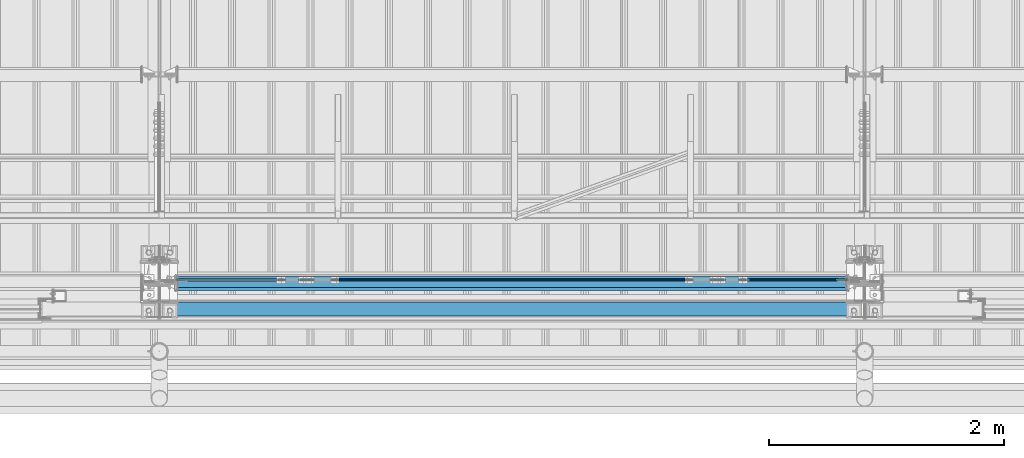
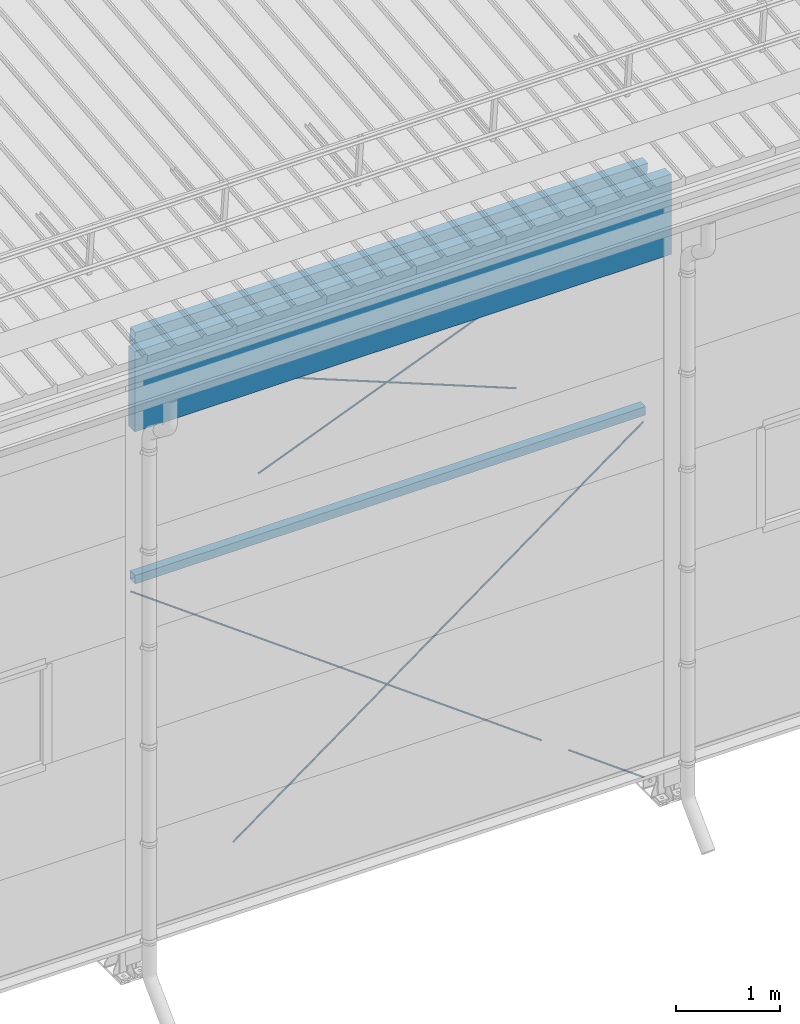
# One storey, part 253 of 709: 5 members, 3 beams, 5 openings, 8 elements without a shape of their own.
"""IFC4 building model written with IfcOpenShell, lengths in millimetres."""

from ifc_helpers import new_model, si_unit, direction, frame, origin_with_axes, place, context, subcontext, project, spatial, line, indexed_curve, outline, extrude, polygons, material, element, aggregate, save


model = new_model("IFC4")

# Units and contexts
model_context = context("Model", 3, precision=0.2, world=origin_with_axes(), true_north=direction((0.0, 1.0)))
body_context = subcontext(model_context, "Body", "Model", "MODEL_VIEW")
reference_context = subcontext(model_context, "Reference", "Model", "MODEL_VIEW")
ifc_project = project(units=[si_unit("LENGTHUNIT", "METRE", prefix="MILLI"), si_unit("AREAUNIT", "SQUARE_METRE"), si_unit("VOLUMEUNIT", "CUBIC_METRE"), si_unit("MASSUNIT", "GRAM", prefix="KILO"), si_unit("TIMEUNIT", "SECOND"), si_unit("PLANEANGLEUNIT", "RADIAN"), si_unit("SOLIDANGLEUNIT", "STERADIAN"), si_unit("THERMODYNAMICTEMPERATUREUNIT", "DEGREE_CELSIUS"), si_unit("LUMINOUSINTENSITYUNIT", "LUMEN")], contexts=[model_context])

# Site, building, storey
site_placement = place(None, origin_with_axes())
site = spatial("IfcSite", under=ifc_project, at=site_placement, CompositionType="ELEMENT")
building_placement = place(site_placement, origin_with_axes())
building = spatial("IfcBuilding", under=site, at=building_placement, Name="Undefined", CompositionType="ELEMENT")
storey_placement = place(building_placement, origin_with_axes())
storey = spatial("IfcBuildingStorey", under=building, at=storey_placement, Name="Undefined", CompositionType="ELEMENT", Elevation=0.0)

# Assembly, beam
assembly_1_placement = place(storey_placement, frame((22000.0, 173.0, 4310.0), z_axis=(0.0, 0.0, -1.0), x_axis=(1.0, 0.0, 0.0)))
assembly_1 = element("IfcElementAssembly", 1, at=assembly_1_placement, inside=storey)
ifc_material_1 = material(Name="C355", Category="STEEL")
beam_1_placement = place(assembly_1_placement, origin_with_axes())
beam_1 = element("IfcBeam", 2, at=beam_1_placement, material=ifc_material_1, ObjectType="546", context=body_context, shape_type="Tessellation", body=[
    polygons([(155.0, -47.0, -47.0), (155.0, -47.0, 47.0), (5845.0, -47.0, 47.0), (5845.0, -47.0, -47.0), (155.0, 47.0, 47.0), (5845.0, 47.0, 47.0), (155.0, 47.0, -47.0), (5845.0, 47.0, -47.0), (155.0, -50.0, -50.0), (155.0, 50.0, -50.0), (5845.0, 50.0, -50.0), (5845.0, -50.0, -50.0), (155.0, 50.0, 50.0), (5845.0, 50.0, 50.0), (155.0, -50.0, 50.0), (5845.0, -50.0, 50.0)], [[[1, 2, 3, 4]], [[2, 5, 6, 3]], [[5, 7, 8, 6]], [[7, 1, 4, 8]], [[9, 10, 11, 12]], [[10, 13, 14, 11]], [[13, 15, 16, 14]], [[15, 9, 12, 16]], [[14, 16, 12, 11], [6, 8, 4, 3]], [[15, 13, 10, 9], [7, 5, 2, 1]]], closed=True),
])
aggregate(assembly_1, [beam_1])

# Assembly, member, voiding feature
assembly_2_placement = place(storey_placement, frame((23129.07626, 189.0, 672.76012), z_axis=(0.0, -1.0, 0.0), x_axis=(0.8064830392, 0.0, 0.5912572262)))
assembly_2 = element("IfcElementAssembly", 3, at=assembly_2_placement, inside=storey)
ifc_material_2 = material(Name="C355-5", Category="STEEL")
member_1_placement = place(assembly_2_placement, origin_with_axes())
member_1 = element("IfcMember", 4, at=member_1_placement, material=ifc_material_2, ObjectType="549", context=body_context, shape_type="Tessellation", body=[
    polygons([(5861.83429, -5.0, 8.66025), (5861.83429, -7.07107, 7.07107), (5861.83429, -8.66025, 5.0), (5861.83429, -9.65926, 2.58819), (5861.83429, -10.0, 0.0), (5861.83429, -9.65926, -2.58819), (5861.83429, -8.66025, -5.0), (5861.83429, -7.07107, -7.07107), (5861.83429, -5.0, -8.66025), (5861.83429, -2.58819, -9.65926), (5861.83429, 0.0, -10.0), (5861.83429, 2.58819, -9.65926), (5861.83429, 5.0, -8.66025), (5861.83429, 7.07107, -7.07107), (5861.83429, 8.66025, -5.0), (5861.83429, 9.65926, -2.58819), (5861.83429, 10.0, 0.0), (5861.83429, 9.65926, 2.58819), (5861.83429, 8.66025, 5.0), (5861.83429, 7.07107, 7.07107), (5861.83429, 5.0, 8.66025), (5861.83429, 2.58819, 9.65926), (5861.83429, 0.0, 10.0), (5861.83429, -2.58819, 9.65926), (190.0, 10.0, 0.0), (190.0, 9.65926, 2.58819), (190.0, 8.66025, 5.0), (190.0, 7.07107, 7.07107), (190.0, 5.0, 8.66025), (190.0, 2.58819, 9.65926), (190.0, 0.0, 10.0), (190.0, -2.58819, 9.65926), (190.0, -5.0, 8.66025), (190.0, -7.07107, 7.07107), (190.0, -8.66025, 5.0), (190.0, -9.65926, 2.58819), (190.0, -10.0, 0.0), (190.0, -9.65926, -2.58819), (190.0, -8.66025, -5.0), (190.0, -7.07107, -7.07107), (190.0, -5.0, -8.66025), (190.0, -2.58819, -9.65926), (190.0, 0.0, -10.0), (190.0, 2.58819, -9.65926), (190.0, 5.0, -8.66025), (190.0, 7.07107, -7.07107), (190.0, 8.66025, -5.0), (190.0, 9.65926, -2.58819), (10.0, 7.36122, 4.25), (190.0, 7.36122, 4.25), (190.0, 8.21037, 2.19996), (10.0, 8.21037, 2.19996), (10.0, 6.01041, 6.01041), (190.0, 6.01041, 6.01041), (10.0, 4.25, 7.36122), (190.0, 4.25, 7.36122), (10.0, 2.19996, 8.21037), (190.0, 2.19996, 8.21037), (10.0, 0.0, 8.5), (190.0, 0.0, 8.5), (10.0, -2.19996, 8.21037), (190.0, -2.19996, 8.21037), (10.0, -4.25, 7.36122), (190.0, -4.25, 7.36122), (10.0, -6.01041, 6.01041), (190.0, -6.01041, 6.01041), (10.0, -7.36122, 4.25), (190.0, -7.36122, 4.25), (10.0, -8.21037, 2.19996), (190.0, -8.21037, 2.19996), (10.0, -8.5, 0.0), (190.0, -8.5, 0.0), (10.0, -8.21037, -2.19996), (190.0, -8.21037, -2.19996), (10.0, -7.36122, -4.25), (190.0, -7.36122, -4.25), (10.0, -6.01041, -6.01041), (190.0, -6.01041, -6.01041), (10.0, -4.25, -7.36122), (190.0, -4.25, -7.36122), (10.0, -2.19996, -8.21037), (190.0, -2.19996, -8.21037), (10.0, 0.0, -8.5), (190.0, 0.0, -8.5), (10.0, 2.19996, -8.21037), (190.0, 2.19996, -8.21037), (10.0, 4.25, -7.36122), (190.0, 4.25, -7.36122), (10.0, 6.01041, -6.01041), (190.0, 6.01041, -6.01041), (10.0, 7.36122, -4.25), (190.0, 7.36122, -4.25), (10.0, 8.21037, -2.19996), (190.0, 8.21037, -2.19996), (10.0, 8.5, 0.0), (190.0, 8.5, 0.0)], [[[1, 2, 3, 4, 5, 6, 7, 8, 9, 10, 11, 12, 13, 14, 15, 16, 17, 18, 19, 20, 21, 22, 23, 24]], [[18, 17, 25, 26]], [[19, 18, 26, 27]], [[20, 19, 27, 28]], [[21, 20, 28, 29]], [[22, 21, 29, 30]], [[23, 22, 30, 31]], [[24, 23, 31, 32]], [[1, 24, 32, 33]], [[2, 1, 33, 34]], [[3, 2, 34, 35]], [[4, 3, 35, 36]], [[5, 4, 36, 37]], [[6, 5, 37, 38]], [[7, 6, 38, 39]], [[8, 7, 39, 40]], [[9, 8, 40, 41]], [[10, 9, 41, 42]], [[11, 10, 42, 43]], [[12, 11, 43, 44]], [[13, 12, 44, 45]], [[14, 13, 45, 46]], [[15, 14, 46, 47]], [[16, 15, 47, 48]], [[17, 16, 48, 25]], [[25, 48, 47, 46, 45, 44, 43, 42, 41, 40, 39, 38, 37, 36, 35, 34, 33, 32, 31, 30, 29, 28, 27, 26], [74, 76, 78, 80, 82, 84, 86, 88, 90, 92, 94, 96, 51, 50, 54, 56, 58, 60, 62, 64, 66, 68, 70, 72]], [[49, 50, 51, 52]], [[53, 54, 50, 49]], [[55, 56, 54, 53]], [[57, 58, 56, 55]], [[59, 60, 58, 57]], [[61, 62, 60, 59]], [[63, 64, 62, 61]], [[65, 66, 64, 63]], [[67, 68, 66, 65]], [[69, 70, 68, 67]], [[71, 72, 70, 69]], [[73, 74, 72, 71]], [[75, 76, 74, 73]], [[77, 78, 76, 75]], [[79, 80, 78, 77]], [[81, 82, 80, 79]], [[83, 84, 82, 81]], [[85, 86, 84, 83]], [[87, 88, 86, 85]], [[89, 90, 88, 87]], [[91, 92, 90, 89]], [[93, 94, 92, 91]], [[95, 96, 94, 93]], [[52, 51, 96, 95]], [[91, 89, 87, 85, 83, 81, 79, 77, 75, 73, 71, 69, 67, 65, 63, 61, 59, 57, 55, 53, 49, 52, 95, 93]]], closed=True),
])
voiding_feature_1_placement = place(member_1_placement, frame((10.0, 0.0, 0.0), z_axis=(0.0, -1.0, 0.0), x_axis=(1.0, 0.0, 0.0)))
element("IfcVoidingFeature", 5, at=voiding_feature_1_placement, cuts=member_1, PredefinedType="HOLE", context=reference_context, identifier="Reference", shape_type="SolidModel", body=[
    extrude(outline(indexed_curve([(10.5, 0.0), (10.14222, 2.7176), (9.09327, 5.25), (7.42462, 7.42462), (5.25, 9.09327), (2.7176, 10.14222), (0.0, 10.5), (-2.7176, 10.14222), (-5.25, 9.09327), (-7.42462, 7.42462), (-9.09327, 5.25), (-10.14222, 2.7176), (-10.5, 0.0), (-10.14222, -2.7176), (-9.09327, -5.25), (-7.42462, -7.42462), (-5.25, -9.09327), (-2.7176, -10.14222), (0.0, -10.5), (2.7176, -10.14222), (5.25, -9.09327), (7.42462, -7.42462), (9.09327, -5.25), (10.14222, -2.7176)], segments=[line(1, 2, 3, 4, 5, 6, 7, 8, 9, 10, 11, 12, 13, 14, 15, 16, 17, 18, 19, 20, 21, 22, 23, 24, 1)])), frame((0.0, 0.0, 0.0), z_axis=(-1.0, 0.0, 0.0), x_axis=(0.0, 0.0, 1.0)), (0.0, 0.0, -1.0), 180.0),
])
aggregate(assembly_2, [member_1])

assembly_3_placement = place(storey_placement, frame((22087.0, 189.0, 4180.0), z_axis=(0.0, -1.0, 0.0), x_axis=(0.8064830392, 0.0, -0.5912572261)))
assembly_3 = element("IfcElementAssembly", 6, at=assembly_3_placement, inside=storey)
member_2_placement = place(assembly_3_placement, origin_with_axes())
member_2 = element("IfcMember", 7, at=member_2_placement, material=ifc_material_2, ObjectType="549", context=body_context, shape_type="Tessellation", body=[
    polygons([(5921.83429, 7.36122, 4.25), (5921.83429, 6.01041, 6.01041), (5921.83429, 4.25, 7.36122), (5921.83429, 2.19996, 8.21037), (5921.83429, 0.0, 8.5), (5921.83429, -2.19996, 8.21037), (5921.83429, -4.25, 7.36122), (5921.83429, -6.0104, 6.01041), (5921.83429, -7.36121, 4.25), (5921.83429, -8.21037, 2.19996), (5921.83429, -8.5, 0.0), (5921.83429, -8.21037, -2.19996), (5921.83429, -7.36121, -4.25), (5921.83429, -6.0104, -6.01041), (5921.83429, -4.25, -7.36122), (5921.83429, -2.19996, -8.21037), (5921.83429, 0.0, -8.5), (5921.83429, 2.19996, -8.21037), (5921.83429, 4.25, -7.36122), (5921.83429, 6.01041, -6.01041), (5921.83429, 7.36122, -4.25), (5921.83429, 8.21037, -2.19996), (5921.83429, 8.5, 0.0), (5921.83429, 8.21037, 2.19996), (5741.83429, 8.21037, 2.19996), (5741.83429, 7.36122, 4.25), (5741.83429, 6.01041, 6.01041), (5741.83429, 4.25, 7.36122), (5741.83429, 2.19996, 8.21037), (5741.83429, 0.0, 8.5), (5741.83429, -2.19996, 8.21037), (5741.83429, -4.25, 7.36122), (5741.83429, -6.0104, 6.01041), (5741.83429, -7.36121, 4.25), (5741.83429, -8.21037, 2.19996), (5741.83429, -8.5, 0.0), (5741.83429, -8.21037, -2.19996), (5741.83429, -7.36121, -4.25), (5741.83429, -6.0104, -6.01041), (5741.83429, -4.25, -7.36122), (5741.83429, -2.19996, -8.21037), (5741.83429, 0.0, -8.5), (5741.83429, 2.19996, -8.21037), (5741.83429, 4.25, -7.36122), (5741.83429, 6.01041, -6.01041), (5741.83429, 7.36122, -4.25), (5741.83429, 8.21037, -2.19996), (5741.83429, 8.5, 0.0), (5741.83429, 10.0, 0.0), (5741.83429, 9.65926, 2.58819), (5741.83429, 8.66025, 5.0), (5741.83429, 7.07107, 7.07107), (5741.83429, 5.0, 8.66025), (5741.83429, 2.58819, 9.65926), (5741.83429, 0.0, 10.0), (5741.83429, -2.58819, 9.65926), (5741.83429, -5.0, 8.66025), (5741.83429, -7.07107, 7.07107), (5741.83429, -8.66025, 5.0), (5741.83429, -9.65926, 2.58819), (5741.83429, -10.0, 0.0), (5741.83429, -9.65926, -2.58819), (5741.83429, -8.66025, -5.0), (5741.83429, -7.07107, -7.07107), (5741.83429, -5.0, -8.66025), (5741.83429, -2.58819, -9.65926), (5741.83429, 0.0, -10.0), (5741.83429, 2.58819, -9.65926), (5741.83429, 5.0, -8.66025), (5741.83429, 7.07107, -7.07107), (5741.83429, 8.66025, -5.0), (5741.83429, 9.65926, -2.58819), (70.0, 2.58819, 9.65926), (70.0, 5.0, 8.66025), (70.0, 7.07107, 7.07107), (70.0, 8.66025, 5.0), (70.0, 9.65926, 2.58819), (70.0, 10.0, 0.0), (70.0, 9.65926, -2.58819), (70.0, 8.66025, -5.0), (70.0, 7.07107, -7.07107), (70.0, 5.0, -8.66025), (70.0, 2.58819, -9.65926), (70.0, 0.0, -10.0), (70.0, -2.58819, -9.65926), (70.0, -5.0, -8.66025), (70.0, -7.07107, -7.07107), (70.0, -8.66025, -5.0), (70.0, -9.65926, -2.58819), (70.0, -10.0, 0.0), (70.0, -9.65926, 2.58819), (70.0, -8.66025, 5.0), (70.0, -7.07107, 7.07107), (70.0, -5.0, 8.66025), (70.0, -2.58819, 9.65926), (70.0, 0.0, 10.0)], [[[1, 2, 3, 4, 5, 6, 7, 8, 9, 10, 11, 12, 13, 14, 15, 16, 17, 18, 19, 20, 21, 22, 23, 24]], [[24, 25, 26, 1]], [[1, 26, 27, 2]], [[2, 27, 28, 3]], [[3, 28, 29, 4]], [[4, 29, 30, 5]], [[5, 30, 31, 6]], [[6, 31, 32, 7]], [[7, 32, 33, 8]], [[8, 33, 34, 9]], [[9, 34, 35, 10]], [[10, 35, 36, 11]], [[11, 36, 37, 12]], [[12, 37, 38, 13]], [[13, 38, 39, 14]], [[14, 39, 40, 15]], [[15, 40, 41, 16]], [[16, 41, 42, 17]], [[17, 42, 43, 18]], [[18, 43, 44, 19]], [[19, 44, 45, 20]], [[20, 45, 46, 21]], [[21, 46, 47, 22]], [[22, 47, 48, 23]], [[23, 48, 25, 24]], [[49, 50, 51, 52, 53, 54, 55, 56, 57, 58, 59, 60, 61, 62, 63, 64, 65, 66, 67, 68, 69, 70, 71, 72], [47, 46, 45, 44, 43, 42, 41, 40, 39, 38, 37, 36, 35, 34, 33, 32, 31, 30, 29, 28, 27, 26, 25, 48]], [[73, 74, 75, 76, 77, 78, 79, 80, 81, 82, 83, 84, 85, 86, 87, 88, 89, 90, 91, 92, 93, 94, 95, 96]], [[79, 78, 49, 72]], [[80, 79, 72, 71]], [[81, 80, 71, 70]], [[82, 81, 70, 69]], [[83, 82, 69, 68]], [[84, 83, 68, 67]], [[85, 84, 67, 66]], [[86, 85, 66, 65]], [[87, 86, 65, 64]], [[88, 87, 64, 63]], [[89, 88, 63, 62]], [[90, 89, 62, 61]], [[91, 90, 61, 60]], [[92, 91, 60, 59]], [[93, 92, 59, 58]], [[94, 93, 58, 57]], [[95, 94, 57, 56]], [[96, 95, 56, 55]], [[73, 96, 55, 54]], [[74, 73, 54, 53]], [[75, 74, 53, 52]], [[76, 75, 52, 51]], [[77, 76, 51, 50]], [[78, 77, 50, 49]]], closed=True),
])
voiding_feature_2_placement = place(member_2_placement, frame((5921.83429, 0.0, 0.0), z_axis=(0.0, 1.0, 0.0), x_axis=(-1.0, 0.0, 0.0)))
element("IfcVoidingFeature", 8, at=voiding_feature_2_placement, cuts=member_2, PredefinedType="HOLE", context=reference_context, identifier="Reference", shape_type="SolidModel", body=[
    extrude(outline(indexed_curve([(10.5, 0.0), (10.14222, 2.7176), (9.09327, 5.25), (7.42462, 7.42462), (5.25, 9.09327), (2.7176, 10.14222), (0.0, 10.5), (-2.7176, 10.14222), (-5.25, 9.09327), (-7.42462, 7.42462), (-9.09327, 5.25), (-10.14222, 2.7176), (-10.5, 0.0), (-10.14222, -2.7176), (-9.09327, -5.25), (-7.42462, -7.42462), (-5.25, -9.09327), (-2.7176, -10.14222), (0.0, -10.5), (2.7176, -10.14222), (5.25, -9.09327), (7.42462, -7.42462), (9.09327, -5.25), (10.14222, -2.7176)], segments=[line(1, 2, 3, 4, 5, 6, 7, 8, 9, 10, 11, 12, 13, 14, 15, 16, 17, 18, 19, 20, 21, 22, 23, 24, 1)])), frame((0.0, 0.0, 0.0), z_axis=(-1.0, 0.0, 0.0), x_axis=(0.0, 0.0, 1.0)), (0.0, 0.0, -1.0), 180.0),
])
aggregate(assembly_3, [member_2])

assembly_4_placement = place(storey_placement, frame((26870.92374, 189.0, 672.76012), z_axis=(0.0, -1.0, 0.0), x_axis=(0.8064830392, 0.0, -0.5912572261)))
assembly_4 = element("IfcElementAssembly", 9, at=assembly_4_placement, inside=storey)
member_3_placement = place(assembly_4_placement, origin_with_axes())
member_3 = element("IfcMember", 10, at=member_3_placement, material=ifc_material_2, ObjectType="548", context=body_context, shape_type="Tessellation", body=[
    polygons([(1225.82155, -5.0, 8.66025), (1225.82155, -7.07107, 7.07107), (1225.82155, -8.66025, 5.0), (1225.82155, -9.65926, 2.58819), (1225.82155, -10.0, 0.0), (1225.82155, -9.65926, -2.58819), (1225.82155, -8.66025, -5.0), (1225.82155, -7.07107, -7.07107), (1225.82155, -5.0, -8.66025), (1225.82155, -2.58819, -9.65926), (1225.82155, 0.0, -10.0), (1225.82155, 2.58819, -9.65926), (1225.82155, 5.0, -8.66025), (1225.82155, 7.07107, -7.07107), (1225.82155, 8.66025, -5.0), (1225.82155, 9.65926, -2.58819), (1225.82155, 10.0, 0.0), (1225.82155, 9.65926, 2.58819), (1225.82155, 8.66025, 5.0), (1225.82155, 7.07107, 7.07107), (1225.82155, 5.0, 8.66025), (1225.82155, 2.58819, 9.65926), (1225.82155, 0.0, 10.0), (1225.82155, -2.58819, 9.65926), (190.0, 10.0, 0.0), (190.0, 9.65926, 2.58819), (190.0, 8.66025, 5.0), (190.0, 7.07107, 7.07107), (190.0, 5.0, 8.66025), (190.0, 2.58819, 9.65926), (190.0, 0.0, 10.0), (190.0, -2.58819, 9.65926), (190.0, -5.0, 8.66025), (190.0, -7.07107, 7.07107), (190.0, -8.66025, 5.0), (190.0, -9.65926, 2.58819), (190.0, -10.0, 0.0), (190.0, -9.65926, -2.58819), (190.0, -8.66025, -5.0), (190.0, -7.07107, -7.07107), (190.0, -5.0, -8.66025), (190.0, -2.58819, -9.65926), (190.0, 0.0, -10.0), (190.0, 2.58819, -9.65926), (190.0, 5.0, -8.66025), (190.0, 7.07107, -7.07107), (190.0, 8.66025, -5.0), (190.0, 9.65926, -2.58819), (10.0, 7.36122, 4.25), (190.0, 7.36122, 4.25), (190.0, 8.21037, 2.19996), (10.0, 8.21037, 2.19996), (10.0, 6.01041, 6.01041), (190.0, 6.01041, 6.01041), (10.0, 4.25, 7.36122), (190.0, 4.25, 7.36122), (10.0, 2.19996, 8.21037), (190.0, 2.19996, 8.21037), (10.0, 0.0, 8.5), (190.0, 0.0, 8.5), (10.0, -2.19996, 8.21037), (190.0, -2.19996, 8.21037), (10.0, -4.25, 7.36122), (190.0, -4.25, 7.36122), (10.0, -6.01041, 6.01041), (190.0, -6.01041, 6.01041), (10.0, -7.36122, 4.25), (190.0, -7.36122, 4.25), (10.0, -8.21037, 2.19996), (190.0, -8.21037, 2.19996), (10.0, -8.5, 0.0), (190.0, -8.5, 0.0), (10.0, -8.21037, -2.19996), (190.0, -8.21037, -2.19996), (10.0, -7.36122, -4.25), (190.0, -7.36122, -4.25), (10.0, -6.01041, -6.01041), (190.0, -6.01041, -6.01041), (10.0, -4.25, -7.36122), (190.0, -4.25, -7.36122), (10.0, -2.19996, -8.21037), (190.0, -2.19996, -8.21037), (10.0, 0.0, -8.5), (190.0, 0.0, -8.5), (10.0, 2.19996, -8.21037), (190.0, 2.19996, -8.21037), (10.0, 4.25, -7.36122), (190.0, 4.25, -7.36122), (10.0, 6.01041, -6.01041), (190.0, 6.01041, -6.01041), (10.0, 7.36122, -4.25), (190.0, 7.36122, -4.25), (10.0, 8.21037, -2.19996), (190.0, 8.21037, -2.19996), (10.0, 8.5, 0.0), (190.0, 8.5, 0.0)], [[[1, 2, 3, 4, 5, 6, 7, 8, 9, 10, 11, 12, 13, 14, 15, 16, 17, 18, 19, 20, 21, 22, 23, 24]], [[18, 17, 25, 26]], [[19, 18, 26, 27]], [[20, 19, 27, 28]], [[21, 20, 28, 29]], [[22, 21, 29, 30]], [[23, 22, 30, 31]], [[24, 23, 31, 32]], [[1, 24, 32, 33]], [[2, 1, 33, 34]], [[3, 2, 34, 35]], [[4, 3, 35, 36]], [[5, 4, 36, 37]], [[6, 5, 37, 38]], [[7, 6, 38, 39]], [[8, 7, 39, 40]], [[9, 8, 40, 41]], [[10, 9, 41, 42]], [[11, 10, 42, 43]], [[12, 11, 43, 44]], [[13, 12, 44, 45]], [[14, 13, 45, 46]], [[15, 14, 46, 47]], [[16, 15, 47, 48]], [[17, 16, 48, 25]], [[25, 48, 47, 46, 45, 44, 43, 42, 41, 40, 39, 38, 37, 36, 35, 34, 33, 32, 31, 30, 29, 28, 27, 26], [74, 76, 78, 80, 82, 84, 86, 88, 90, 92, 94, 96, 51, 50, 54, 56, 58, 60, 62, 64, 66, 68, 70, 72]], [[49, 50, 51, 52]], [[53, 54, 50, 49]], [[55, 56, 54, 53]], [[57, 58, 56, 55]], [[59, 60, 58, 57]], [[61, 62, 60, 59]], [[63, 64, 62, 61]], [[65, 66, 64, 63]], [[67, 68, 66, 65]], [[69, 70, 68, 67]], [[71, 72, 70, 69]], [[73, 74, 72, 71]], [[75, 76, 74, 73]], [[77, 78, 76, 75]], [[79, 80, 78, 77]], [[81, 82, 80, 79]], [[83, 84, 82, 81]], [[85, 86, 84, 83]], [[87, 88, 86, 85]], [[89, 90, 88, 87]], [[91, 92, 90, 89]], [[93, 94, 92, 91]], [[95, 96, 94, 93]], [[52, 51, 96, 95]], [[91, 89, 87, 85, 83, 81, 79, 77, 75, 73, 71, 69, 67, 65, 63, 61, 59, 57, 55, 53, 49, 52, 95, 93]]], closed=True),
])
voiding_feature_3_placement = place(member_3_placement, frame((10.0, 0.0, 0.0), z_axis=(0.0, -1.0, 0.0), x_axis=(1.0, 0.0, 0.0)))
element("IfcVoidingFeature", 11, at=voiding_feature_3_placement, cuts=member_3, PredefinedType="HOLE", context=reference_context, identifier="Reference", shape_type="SolidModel", body=[
    extrude(outline(indexed_curve([(10.5, 0.0), (10.14222, 2.7176), (9.09327, 5.25), (7.42462, 7.42462), (5.25, 9.09327), (2.7176, 10.14222), (0.0, 10.5), (-2.7176, 10.14222), (-5.25, 9.09327), (-7.42462, 7.42462), (-9.09327, 5.25), (-10.14222, 2.7176), (-10.5, 0.0), (-10.14222, -2.7176), (-9.09327, -5.25), (-7.42462, -7.42462), (-5.25, -9.09327), (-2.7176, -10.14222), (0.0, -10.5), (2.7176, -10.14222), (5.25, -9.09327), (7.42462, -7.42462), (9.09327, -5.25), (10.14222, -2.7176)], segments=[line(1, 2, 3, 4, 5, 6, 7, 8, 9, 10, 11, 12, 13, 14, 15, 16, 17, 18, 19, 20, 21, 22, 23, 24, 1)])), frame((0.0, 0.0, 0.0), z_axis=(-1.0, 0.0, 0.0), x_axis=(0.0, 0.0, 1.0)), (0.0, 0.0, -1.0), 180.0),
])
aggregate(assembly_4, [member_3])

assembly_5_placement = place(storey_placement, frame((23387.0491, 189.0, 4959.49238), z_axis=(0.0, -1.0, 0.0), x_axis=(0.9286065, 0.0, 0.371065989)))
assembly_5 = element("IfcElementAssembly", 12, at=assembly_5_placement, inside=storey)
member_4_placement = place(assembly_5_placement, origin_with_axes())
member_4 = element("IfcMember", 13, at=member_4_placement, material=ifc_material_2, ObjectType="550", context=body_context, shape_type="Tessellation", body=[
    polygons([(4830.84953, -5.0, 8.66025), (4830.84953, -7.07107, 7.07107), (4830.84953, -8.66025, 5.0), (4830.84953, -9.65926, 2.58819), (4830.84953, -10.0, 0.0), (4830.84953, -9.65926, -2.58819), (4830.84953, -8.66025, -5.0), (4830.84953, -7.07107, -7.07107), (4830.84953, -5.0, -8.66025), (4830.84953, -2.58819, -9.65926), (4830.84953, 0.0, -10.0), (4830.84953, 2.58819, -9.65926), (4830.84953, 5.0, -8.66025), (4830.84953, 7.07107, -7.07107), (4830.84953, 8.66025, -5.0), (4830.84953, 9.65926, -2.58819), (4830.84953, 10.0, 0.0), (4830.84953, 9.65926, 2.58819), (4830.84953, 8.66025, 5.0), (4830.84953, 7.07107, 7.07107), (4830.84953, 5.0, 8.66025), (4830.84953, 2.58819, 9.65926), (4830.84953, 0.0, 10.0), (4830.84953, -2.58819, 9.65926), (190.0, 10.0, 0.0), (190.0, 9.65926, 2.58819), (190.0, 8.66025, 5.0), (190.0, 7.07107, 7.07107), (190.0, 5.0, 8.66025), (190.0, 2.58819, 9.65926), (190.0, 0.0, 10.0), (190.0, -2.58819, 9.65926), (190.0, -5.0, 8.66025), (190.0, -7.07107, 7.07107), (190.0, -8.66025, 5.0), (190.0, -9.65926, 2.58819), (190.0, -10.0, 0.0), (190.0, -9.65926, -2.58819), (190.0, -8.66025, -5.0), (190.0, -7.07107, -7.07107), (190.0, -5.0, -8.66025), (190.0, -2.58819, -9.65926), (190.0, 0.0, -10.0), (190.0, 2.58819, -9.65926), (190.0, 5.0, -8.66025), (190.0, 7.07107, -7.07107), (190.0, 8.66025, -5.0), (190.0, 9.65926, -2.58819), (10.0, 7.36122, 4.25), (190.0, 7.36122, 4.25), (190.0, 8.21037, 2.19996), (10.0, 8.21037, 2.19996), (10.0, 6.01041, 6.01041), (190.0, 6.01041, 6.01041), (10.0, 4.25, 7.36122), (190.0, 4.25, 7.36122), (10.0, 2.19996, 8.21037), (190.0, 2.19996, 8.21037), (10.0, 0.0, 8.5), (190.0, 0.0, 8.5), (10.0, -2.19996, 8.21037), (190.0, -2.19996, 8.21037), (10.0, -4.25, 7.36122), (190.0, -4.25, 7.36122), (10.0, -6.01041, 6.01041), (190.0, -6.01041, 6.01041), (10.0, -7.36122, 4.25), (190.0, -7.36122, 4.25), (10.0, -8.21037, 2.19996), (190.0, -8.21037, 2.19996), (10.0, -8.5, 0.0), (190.0, -8.5, 0.0), (10.0, -8.21037, -2.19996), (190.0, -8.21037, -2.19996), (10.0, -7.36122, -4.25), (190.0, -7.36122, -4.25), (10.0, -6.01041, -6.01041), (190.0, -6.01041, -6.01041), (10.0, -4.25, -7.36122), (190.0, -4.25, -7.36122), (10.0, -2.19996, -8.21037), (190.0, -2.19996, -8.21037), (10.0, 0.0, -8.5), (190.0, 0.0, -8.5), (10.0, 2.19996, -8.21037), (190.0, 2.19996, -8.21037), (10.0, 4.25, -7.36122), (190.0, 4.25, -7.36122), (10.0, 6.01041, -6.01041), (190.0, 6.01041, -6.01041), (10.0, 7.36122, -4.25), (190.0, 7.36122, -4.25), (10.0, 8.21037, -2.19996), (190.0, 8.21037, -2.19996), (10.0, 8.5, 0.0), (190.0, 8.5, 0.0)], [[[1, 2, 3, 4, 5, 6, 7, 8, 9, 10, 11, 12, 13, 14, 15, 16, 17, 18, 19, 20, 21, 22, 23, 24]], [[18, 17, 25, 26]], [[19, 18, 26, 27]], [[20, 19, 27, 28]], [[21, 20, 28, 29]], [[22, 21, 29, 30]], [[23, 22, 30, 31]], [[24, 23, 31, 32]], [[1, 24, 32, 33]], [[2, 1, 33, 34]], [[3, 2, 34, 35]], [[4, 3, 35, 36]], [[5, 4, 36, 37]], [[6, 5, 37, 38]], [[7, 6, 38, 39]], [[8, 7, 39, 40]], [[9, 8, 40, 41]], [[10, 9, 41, 42]], [[11, 10, 42, 43]], [[12, 11, 43, 44]], [[13, 12, 44, 45]], [[14, 13, 45, 46]], [[15, 14, 46, 47]], [[16, 15, 47, 48]], [[17, 16, 48, 25]], [[25, 48, 47, 46, 45, 44, 43, 42, 41, 40, 39, 38, 37, 36, 35, 34, 33, 32, 31, 30, 29, 28, 27, 26], [74, 76, 78, 80, 82, 84, 86, 88, 90, 92, 94, 96, 51, 50, 54, 56, 58, 60, 62, 64, 66, 68, 70, 72]], [[49, 50, 51, 52]], [[53, 54, 50, 49]], [[55, 56, 54, 53]], [[57, 58, 56, 55]], [[59, 60, 58, 57]], [[61, 62, 60, 59]], [[63, 64, 62, 61]], [[65, 66, 64, 63]], [[67, 68, 66, 65]], [[69, 70, 68, 67]], [[71, 72, 70, 69]], [[73, 74, 72, 71]], [[75, 76, 74, 73]], [[77, 78, 76, 75]], [[79, 80, 78, 77]], [[81, 82, 80, 79]], [[83, 84, 82, 81]], [[85, 86, 84, 83]], [[87, 88, 86, 85]], [[89, 90, 88, 87]], [[91, 92, 90, 89]], [[93, 94, 92, 91]], [[95, 96, 94, 93]], [[52, 51, 96, 95]], [[91, 89, 87, 85, 83, 81, 79, 77, 75, 73, 71, 69, 67, 65, 63, 61, 59, 57, 55, 53, 49, 52, 95, 93]]], closed=True),
])
voiding_feature_4_placement = place(member_4_placement, frame((10.0, 0.0, 0.0), z_axis=(0.0, -1.0, 0.0), x_axis=(1.0, 0.0, 0.0)))
element("IfcVoidingFeature", 14, at=voiding_feature_4_placement, cuts=member_4, PredefinedType="HOLE", context=reference_context, identifier="Reference", shape_type="SolidModel", body=[
    extrude(outline(indexed_curve([(10.5, 0.0), (10.14222, 2.7176), (9.09327, 5.25), (7.42462, 7.42462), (5.25, 9.09327), (2.7176, 10.14222), (0.0, 10.5), (-2.7176, 10.14222), (-5.25, 9.09327), (-7.42462, 7.42462), (-9.09327, 5.25), (-10.14222, 2.7176), (-10.5, 0.0), (-10.14222, -2.7176), (-9.09327, -5.25), (-7.42462, -7.42462), (-5.25, -9.09327), (-2.7176, -10.14222), (0.0, -10.5), (2.7176, -10.14222), (5.25, -9.09327), (7.42462, -7.42462), (9.09327, -5.25), (10.14222, -2.7176)], segments=[line(1, 2, 3, 4, 5, 6, 7, 8, 9, 10, 11, 12, 13, 14, 15, 16, 17, 18, 19, 20, 21, 22, 23, 24, 1)])), frame((0.0, 0.0, 0.0), z_axis=(-1.0, 0.0, 0.0), x_axis=(0.0, 0.0, 1.0)), (0.0, 0.0, -1.0), 180.0),
])
aggregate(assembly_5, [member_4])

assembly_6_placement = place(storey_placement, frame((22087.0, 189.0, 6768.03718), z_axis=(0.0, -1.0, 0.0), x_axis=(0.9286065, 0.0, -0.371065989)))
assembly_6 = element("IfcElementAssembly", 15, at=assembly_6_placement, inside=storey)
member_5_placement = place(assembly_6_placement, origin_with_axes())
member_5 = element("IfcMember", 16, at=member_5_placement, material=ifc_material_2, ObjectType="550", context=body_context, shape_type="Tessellation", body=[
    polygons([(4863.91689, 7.36122, 4.25), (4863.91689, 6.01041, 6.01041), (4863.91689, 4.25, 7.36122), (4863.91689, 2.19996, 8.21037), (4863.91689, 0.0, 8.5), (4863.91689, -2.19996, 8.21037), (4863.91689, -4.25, 7.36122), (4863.91689, -6.01041, 6.01041), (4863.91689, -7.36122, 4.25), (4863.91689, -8.21037, 2.19996), (4863.91689, -8.5, 0.0), (4863.91689, -8.21037, -2.19996), (4863.91689, -7.36122, -4.25), (4863.91689, -6.01041, -6.01041), (4863.91689, -4.25, -7.36122), (4863.91689, -2.19996, -8.21037), (4863.91689, 0.0, -8.5), (4863.91689, 2.19996, -8.21037), (4863.91689, 4.25, -7.36122), (4863.91689, 6.01041, -6.01041), (4863.91689, 7.36122, -4.25), (4863.91689, 8.21037, -2.19996), (4863.91689, 8.5, 0.0), (4863.91689, 8.21037, 2.19996), (4683.91689, 8.21037, 2.19996), (4683.91689, 7.36122, 4.25), (4683.91689, 6.01041, 6.01041), (4683.91689, 4.25, 7.36122), (4683.91689, 2.19996, 8.21037), (4683.91689, 0.0, 8.5), (4683.91689, -2.19996, 8.21037), (4683.91689, -4.25, 7.36122), (4683.91689, -6.01041, 6.01041), (4683.91689, -7.36122, 4.25), (4683.91689, -8.21037, 2.19996), (4683.91689, -8.5, 0.0), (4683.91689, -8.21037, -2.19996), (4683.91689, -7.36122, -4.25), (4683.91689, -6.01041, -6.01041), (4683.91689, -4.25, -7.36122), (4683.91689, -2.19996, -8.21037), (4683.91689, 0.0, -8.5), (4683.91689, 2.19996, -8.21037), (4683.91689, 4.25, -7.36122), (4683.91689, 6.01041, -6.01041), (4683.91689, 7.36122, -4.25), (4683.91689, 8.21037, -2.19996), (4683.91689, 8.5, 0.0), (4683.91689, 10.0, 0.0), (4683.91689, 9.65926, 2.58819), (4683.91689, 8.66025, 5.0), (4683.91689, 7.07107, 7.07107), (4683.91689, 5.0, 8.66025), (4683.91689, 2.58819, 9.65926), (4683.91689, 0.0, 10.0), (4683.91689, -2.58819, 9.65926), (4683.91689, -5.0, 8.66025), (4683.91689, -7.07107, 7.07107), (4683.91689, -8.66025, 5.0), (4683.91689, -9.65926, 2.58819), (4683.91689, -10.0, 0.0), (4683.91689, -9.65926, -2.58819), (4683.91689, -8.66025, -5.0), (4683.91689, -7.07107, -7.07107), (4683.91689, -5.0, -8.66025), (4683.91689, -2.58819, -9.65926), (4683.91689, 0.0, -10.0), (4683.91689, 2.58819, -9.65926), (4683.91689, 5.0, -8.66025), (4683.91689, 7.07107, -7.07107), (4683.91689, 8.66025, -5.0), (4683.91689, 9.65926, -2.58819), (43.06736, 2.58819, 9.65926), (43.06736, 5.0, 8.66025), (43.06736, 7.07107, 7.07107), (43.06736, 8.66025, 5.0), (43.06736, 9.65926, 2.58819), (43.06736, 10.0, 0.0), (43.06736, 9.65926, -2.58819), (43.06736, 8.66025, -5.0), (43.06736, 7.07107, -7.07107), (43.06736, 5.0, -8.66025), (43.06736, 2.58819, -9.65926), (43.06736, 0.0, -10.0), (43.06736, -2.58819, -9.65926), (43.06736, -5.0, -8.66025), (43.06736, -7.07107, -7.07107), (43.06736, -8.66025, -5.0), (43.06736, -9.65926, -2.58819), (43.06736, -10.0, 0.0), (43.06736, -9.65926, 2.58819), (43.06736, -8.66025, 5.0), (43.06736, -7.07107, 7.07107), (43.06736, -5.0, 8.66025), (43.06736, -2.58819, 9.65926), (43.06736, 0.0, 10.0)], [[[1, 2, 3, 4, 5, 6, 7, 8, 9, 10, 11, 12, 13, 14, 15, 16, 17, 18, 19, 20, 21, 22, 23, 24]], [[24, 25, 26, 1]], [[1, 26, 27, 2]], [[2, 27, 28, 3]], [[3, 28, 29, 4]], [[4, 29, 30, 5]], [[5, 30, 31, 6]], [[6, 31, 32, 7]], [[7, 32, 33, 8]], [[8, 33, 34, 9]], [[9, 34, 35, 10]], [[10, 35, 36, 11]], [[11, 36, 37, 12]], [[12, 37, 38, 13]], [[13, 38, 39, 14]], [[14, 39, 40, 15]], [[15, 40, 41, 16]], [[16, 41, 42, 17]], [[17, 42, 43, 18]], [[18, 43, 44, 19]], [[19, 44, 45, 20]], [[20, 45, 46, 21]], [[21, 46, 47, 22]], [[22, 47, 48, 23]], [[23, 48, 25, 24]], [[49, 50, 51, 52, 53, 54, 55, 56, 57, 58, 59, 60, 61, 62, 63, 64, 65, 66, 67, 68, 69, 70, 71, 72], [47, 46, 45, 44, 43, 42, 41, 40, 39, 38, 37, 36, 35, 34, 33, 32, 31, 30, 29, 28, 27, 26, 25, 48]], [[73, 74, 75, 76, 77, 78, 79, 80, 81, 82, 83, 84, 85, 86, 87, 88, 89, 90, 91, 92, 93, 94, 95, 96]], [[79, 78, 49, 72]], [[80, 79, 72, 71]], [[81, 80, 71, 70]], [[82, 81, 70, 69]], [[83, 82, 69, 68]], [[84, 83, 68, 67]], [[85, 84, 67, 66]], [[86, 85, 66, 65]], [[87, 86, 65, 64]], [[88, 87, 64, 63]], [[89, 88, 63, 62]], [[90, 89, 62, 61]], [[91, 90, 61, 60]], [[92, 91, 60, 59]], [[93, 92, 59, 58]], [[94, 93, 58, 57]], [[95, 94, 57, 56]], [[96, 95, 56, 55]], [[73, 96, 55, 54]], [[74, 73, 54, 53]], [[75, 74, 53, 52]], [[76, 75, 52, 51]], [[77, 76, 51, 50]], [[78, 77, 50, 49]]], closed=True),
])
voiding_feature_5_placement = place(member_5_placement, frame((4863.91689, 0.0, 0.0), z_axis=(0.0, 1.0, 0.0), x_axis=(-1.0, 0.0, 0.0)))
element("IfcVoidingFeature", 17, at=voiding_feature_5_placement, cuts=member_5, PredefinedType="HOLE", context=reference_context, identifier="Reference", shape_type="SolidModel", body=[
    extrude(outline(indexed_curve([(10.5, 0.0), (10.14222, 2.7176), (9.09327, 5.25), (7.42462, 7.42462), (5.25, 9.09327), (2.7176, 10.14222), (0.0, 10.5), (-2.7176, 10.14222), (-5.25, 9.09327), (-7.42462, 7.42462), (-9.09327, 5.25), (-10.14222, 2.7176), (-10.5, 0.0), (-10.14222, -2.7176), (-9.09327, -5.25), (-7.42462, -7.42462), (-5.25, -9.09327), (-2.7176, -10.14222), (0.0, -10.5), (2.7176, -10.14222), (5.25, -9.09327), (7.42462, -7.42462), (9.09327, -5.25), (10.14222, -2.7176)], segments=[line(1, 2, 3, 4, 5, 6, 7, 8, 9, 10, 11, 12, 13, 14, 15, 16, 17, 18, 19, 20, 21, 22, 23, 24, 1)])), frame((0.0, 0.0, 0.0), z_axis=(-1.0, 0.0, 0.0), x_axis=(0.0, 0.0, 1.0)), (0.0, 0.0, -1.0), 180.0),
])
aggregate(assembly_6, [member_5])

# Assembly, beam
assembly_7_placement = place(storey_placement, frame((22000.0, 158.95533, 7154.40952), z_axis=(0.0, 0.9950371902, 0.099503719), x_axis=(1.0, 0.0, 0.0)))
assembly_7 = element("IfcElementAssembly", 18, at=assembly_7_placement, inside=storey)
beam_2_placement = place(assembly_7_placement, origin_with_axes())
beam_2 = element("IfcBeam", 19, at=beam_2_placement, material=ifc_material_1, ObjectType="578", context=body_context, shape_type="Tessellation", body=[
    polygons([(145.0, -86.0, -46.0), (145.0, -86.0, 46.0), (5855.0, -86.0, 46.0), (5855.0, -86.0, -46.0), (145.0, 86.0, 46.0), (5855.0, 86.0, 46.0), (145.0, 86.0, -46.0), (5855.0, 86.0, -46.0), (145.0, -90.0, -50.0), (145.0, 90.0, -50.0), (5855.0, 90.0, -50.0), (5855.0, -90.0, -50.0), (145.0, 90.0, 50.0), (5855.0, 90.0, 50.0), (145.0, -90.0, 50.0), (5855.0, -90.0, 50.0)], [[[1, 2, 3, 4]], [[2, 5, 6, 3]], [[5, 7, 8, 6]], [[7, 1, 4, 8]], [[9, 10, 11, 12]], [[10, 13, 14, 11]], [[13, 15, 16, 14]], [[15, 9, 12, 16]], [[14, 16, 12, 11], [6, 8, 4, 3]], [[15, 13, 10, 9], [7, 5, 2, 1]]], closed=True),
])
aggregate(assembly_7, [beam_2])

assembly_8_placement = place(storey_placement, frame((22010.0, -60.0, 6845.0), z_axis=(0.0, 0.0, -1.0), x_axis=(1.0, 0.0, 0.0)))
assembly_8 = element("IfcElementAssembly", 20, at=assembly_8_placement, inside=storey)
ifc_material_3 = material(Name="Insulation", Category="Insulation")
beam_3_placement = place(assembly_8_placement, origin_with_axes())
beam_3 = element("IfcBeam", 21, at=beam_3_placement, material=ifc_material_3, ObjectType="P-108", context=body_context, shape_type="Tessellation", body=[
    polygons([(0.0, 60.0, 595.0), (0.0, -60.0, 595.0), (5980.0, -60.0, 595.0), (5980.0, 60.0, 595.0), (5980.0, 60.0, -351.923), (0.0, 60.0, -351.923), (0.0, -60.0, -351.923), (5980.0, -60.0, -351.923)], [[[1, 2, 3, 4]], [[1, 4, 5, 6]], [[2, 1, 6, 7]], [[3, 2, 7, 8]], [[4, 3, 8, 5]], [[7, 6, 5, 8]]], closed=True),
])
aggregate(assembly_8, [beam_3])

save(model, "model.ifc")
